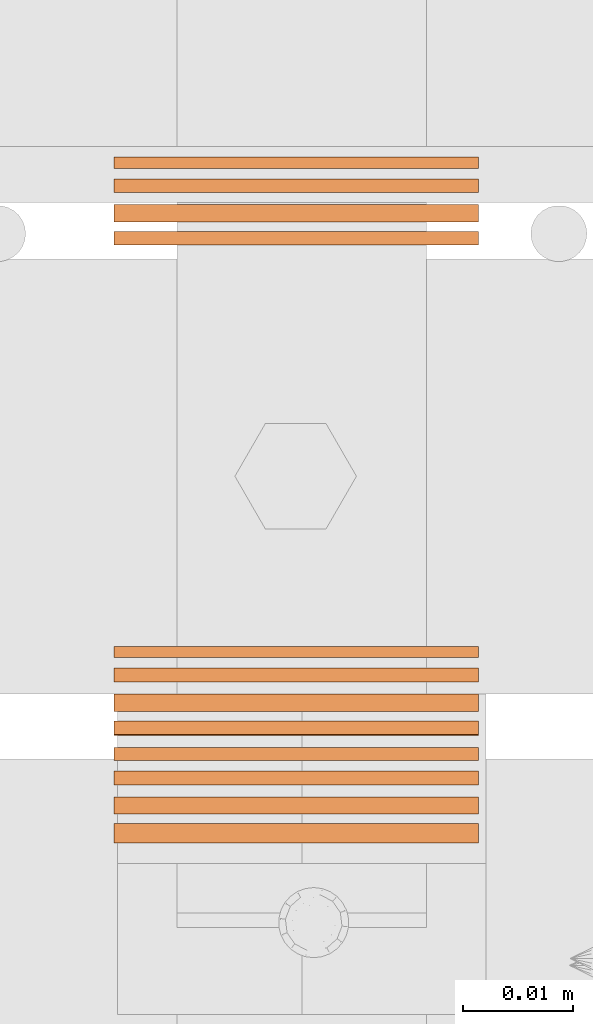
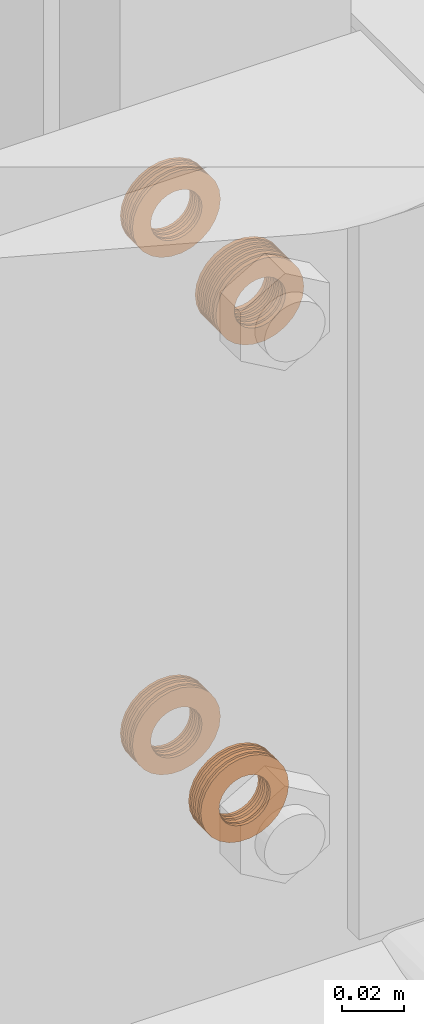
# One storey, part 39 of 44: 5 proxies.
"""IFC4 building model written with IfcOpenShell, lengths in feet."""

from ifc_helpers import new_model, entity, si_unit, converted_unit, derived_unit, direction, frame, frame_2d, origin, origin_2d_with_axis, place, context, subcontext, project, spatial, circle_curve, parameter, trimmed, segment, composite_curve, outline, extrude, source, transform, mapped, material, type_object, type_shapes, element, save


model = new_model("IFC4")

# Units and contexts
model_context = context("Model", 3, precision=0.0001, world=origin(), true_north=direction((6.12303176911189e-17, 1.0)))
body_context = subcontext(model_context, "Body", "Model", "MODEL_VIEW")
ifc_project = project(units=[converted_unit("LENGTHUNIT", "FOOT", entity("IfcRatioMeasure", 0.3048), si_unit("LENGTHUNIT", "METRE"), dimensions=[1, 0, 0, 0, 0, 0, 0]), converted_unit("AREAUNIT", "SQUARE FOOT", entity("IfcRatioMeasure", 0.09290304), si_unit("AREAUNIT", "SQUARE_METRE"), dimensions=[2, 0, 0, 0, 0, 0, 0]), converted_unit("VOLUMEUNIT", "CUBIC FOOT", entity("IfcRatioMeasure", 0.028316846592), si_unit("VOLUMEUNIT", "CUBIC_METRE"), dimensions=[3, 0, 0, 0, 0, 0, 0]), converted_unit("PLANEANGLEUNIT", "DEGREE", entity("IfcRatioMeasure", 0.0174532925199433), si_unit("PLANEANGLEUNIT", "RADIAN"), dimensions=[0, 0, 0, 0, 0, 0, 0]), si_unit("MASSUNIT", "GRAM", prefix="KILO"), derived_unit("MASSDENSITYUNIT", [(si_unit("MASSUNIT", "GRAM", prefix="KILO"), 1), (si_unit("LENGTHUNIT", "METRE"), -3)]), derived_unit("MOMENTOFINERTIAUNIT", [(si_unit("LENGTHUNIT", "METRE"), 4)]), si_unit("TIMEUNIT", "SECOND"), si_unit("FREQUENCYUNIT", "HERTZ"), si_unit("THERMODYNAMICTEMPERATUREUNIT", "DEGREE_CELSIUS"), derived_unit("THERMALTRANSMITTANCEUNIT", [(si_unit("MASSUNIT", "GRAM", prefix="KILO"), 1), (si_unit("THERMODYNAMICTEMPERATUREUNIT", "KELVIN"), -1), (si_unit("TIMEUNIT", "SECOND"), -3)]), derived_unit("VOLUMETRICFLOWRATEUNIT", [(si_unit("LENGTHUNIT", "METRE"), 3), (si_unit("TIMEUNIT", "SECOND"), -1)]), si_unit("ELECTRICCURRENTUNIT", "AMPERE"), si_unit("ELECTRICVOLTAGEUNIT", "VOLT"), si_unit("POWERUNIT", "WATT"), si_unit("FORCEUNIT", "NEWTON"), si_unit("ILLUMINANCEUNIT", "LUX"), si_unit("LUMINOUSFLUXUNIT", "LUMEN"), si_unit("LUMINOUSINTENSITYUNIT", "CANDELA"), derived_unit("USERDEFINED", [(si_unit("MASSUNIT", "GRAM", prefix="KILO"), -1), (si_unit("LENGTHUNIT", "METRE"), -2), (si_unit("TIMEUNIT", "SECOND"), 3), (si_unit("LUMINOUSFLUXUNIT", "LUMEN"), 1)]), derived_unit("LINEARVELOCITYUNIT", [(si_unit("LENGTHUNIT", "METRE"), 1), (si_unit("TIMEUNIT", "SECOND"), -1)]), si_unit("PRESSUREUNIT", "PASCAL"), derived_unit("USERDEFINED", [(si_unit("LENGTHUNIT", "METRE"), -2), (si_unit("MASSUNIT", "GRAM", prefix="KILO"), 1), (si_unit("TIMEUNIT", "SECOND"), -2)]), derived_unit("LINEARFORCEUNIT", [(si_unit("MASSUNIT", "GRAM", prefix="KILO"), 1), (si_unit("LENGTHUNIT", "METRE"), 1), (si_unit("TIMEUNIT", "SECOND"), -2), (si_unit("LENGTHUNIT", "METRE"), -1)]), derived_unit("PLANARFORCEUNIT", [(si_unit("MASSUNIT", "GRAM", prefix="KILO"), 1), (si_unit("LENGTHUNIT", "METRE"), 1), (si_unit("TIMEUNIT", "SECOND"), -2), (si_unit("LENGTHUNIT", "METRE"), -2)])], contexts=[model_context])

# Site, building, storey
site_placement = place(None, origin())
site = spatial("IfcSite", under=ifc_project, at=site_placement, CompositionType="ELEMENT")
building_placement = place(site_placement, origin())
building = spatial("IfcBuilding", under=site, at=building_placement, CompositionType="ELEMENT")
storey_placement = place(building_placement, origin())
storey = spatial("IfcBuildingStorey", under=building, at=storey_placement, CompositionType="ELEMENT", Elevation=0.0)

# Proxies
ifc_material = material(Name="(2) GALV. (FOR DRAINAGE)", Category="Materials")
building_element_proxy_type_1 = type_object("IfcBuildingElementProxyType", Name="WASHER198:WASHER", PredefinedType="NOTDEFINED", material=ifc_material)
shared_shape_1 = source(origin(), body_context, "Body", "SweptSolid", [
    extrude(outline(composite_curve([segment(trimmed(circle_curve(origin_2d_with_axis(), 0.054126587736544), [parameter(360.0)], [parameter(180.0)], True, "PARAMETER"), True, "CONTINUOUS"), segment(trimmed(circle_curve(origin_2d_with_axis(), 0.054126587736544), [parameter(180.0)], [parameter(360.0)], True, "PARAMETER"), True, "CONTINUOUS")], self_intersect=False), holes=[composite_curve([segment(trimmed(circle_curve(frame_2d((0.0, 0.00204962727015712), x_axis=(1.0, 0.0)), 0.031438579453031), [parameter(180.0)], [parameter(360.0)], True, "PARAMETER"), False, "CONTINUOUS"), segment(trimmed(circle_curve(frame_2d((0.0, 0.00204962727015712), x_axis=(1.0, 0.0)), 0.031438579453031), [parameter(360.0)], [parameter(180.0)], True, "PARAMETER"), False, "CONTINUOUS")], self_intersect=False)]), frame((0.0, 0.0593604205315437, 0.0593604205315437), z_axis=(1.0, 0.0, 0.0), x_axis=(0.0, -1.0, 0.0)), (0.0, 0.0, 1.0), 0.00332179672204802),
    extrude(outline(composite_curve([segment(trimmed(circle_curve(origin_2d_with_axis(), 0.054126587736544), [parameter(180.0)], [parameter(360.0)], True, "PARAMETER"), True, "CONTINUOUS"), segment(trimmed(circle_curve(origin_2d_with_axis(), 0.054126587736544), [parameter(360.0)], [parameter(180.0)], True, "PARAMETER"), True, "CONTINUOUS")], self_intersect=False), holes=[composite_curve([segment(trimmed(circle_curve(frame_2d((0.0, 0.00204962727015712), x_axis=(1.0, 0.0)), 0.031438579453031), [parameter(360.0)], [parameter(180.0)], True, "PARAMETER"), False, "CONTINUOUS"), segment(trimmed(circle_curve(frame_2d((0.0, 0.00204962727015712), x_axis=(1.0, 0.0)), 0.031438579453031), [parameter(180.0)], [parameter(360.0)], True, "PARAMETER"), False, "CONTINUOUS")], self_intersect=False)]), frame((0.0220636819910851, 0.0593604205315437, 0.0593604205315437), z_axis=(1.0, 0.0, 0.0), x_axis=(0.0, -1.0, 0.0)), (0.0, 0.0, 1.0), 0.00404999031002262),
    extrude(outline(composite_curve([segment(trimmed(circle_curve(origin_2d_with_axis(), 0.054126587736544), [parameter(180.0)], [parameter(360.0)], True, "PARAMETER"), True, "CONTINUOUS"), segment(trimmed(circle_curve(origin_2d_with_axis(), 0.054126587736544), [parameter(360.0)], [parameter(180.0)], True, "PARAMETER"), True, "CONTINUOUS")], self_intersect=False), holes=[composite_curve([segment(trimmed(circle_curve(frame_2d((0.0, 0.00204962727015712), x_axis=(1.0, 0.0)), 0.031438579453031), [parameter(360.0)], [parameter(180.0)], True, "PARAMETER"), False, "CONTINUOUS"), segment(trimmed(circle_curve(frame_2d((0.0, 0.00204962727015712), x_axis=(1.0, 0.0)), 0.031438579453031), [parameter(180.0)], [parameter(360.0)], True, "PARAMETER"), False, "CONTINUOUS")], self_intersect=False)]), frame((0.00642093526334975, 0.0593604205315437, 0.0593604205315437), z_axis=(1.0, 0.0, 0.0), x_axis=(0.0, -1.0, 0.0)), (0.0, 0.0, 1.0), 0.00412198282083409),
    extrude(outline(composite_curve([segment(trimmed(circle_curve(origin_2d_with_axis(), 0.054126587736544), [parameter(180.0)], [parameter(360.0)], True, "PARAMETER"), True, "CONTINUOUS"), segment(trimmed(circle_curve(origin_2d_with_axis(), 0.054126587736544), [parameter(360.0)], [parameter(180.0)], True, "PARAMETER"), True, "CONTINUOUS")], self_intersect=False), holes=[composite_curve([segment(trimmed(circle_curve(frame_2d((0.0, 0.00204962727015712), x_axis=(1.0, 0.0)), 0.031438579453031), [parameter(360.0)], [parameter(180.0)], True, "PARAMETER"), False, "CONTINUOUS"), segment(trimmed(circle_curve(frame_2d((0.0, 0.00204962727015712), x_axis=(1.0, 0.0)), 0.031438579453031), [parameter(180.0)], [parameter(360.0)], True, "PARAMETER"), False, "CONTINUOUS")], self_intersect=False)]), frame((0.0141095597130061, 0.0593604205315437, 0.0593604205315437), z_axis=(1.0, 0.0, 0.0), x_axis=(0.0, -1.0, 0.0)), (0.0, 0.0, 1.0), 0.0051228935196832),
])
type_shapes(building_element_proxy_type_1, [shared_shape_1])
proxy_1_placement = place(storey_placement, frame((1493.80418979036, 4.9172173612744, 9.5801619472998), z_axis=(0.0, 0.0, 1.0), x_axis=(0.0, -1.0, 0.0)))
element("IfcBuildingElementProxy", 1, at=proxy_1_placement, inside=storey, type_object=building_element_proxy_type_1, material=ifc_material, Name="WASHER198:WASHER", ObjectType="WASHER198:WASHER", PredefinedType="NOTDEFINED", context=body_context, shape_type="MappedRepresentation", body=[
    mapped(shared_shape_1, transform((0.0, 0.0, 0.0), scale=1.0)),
])
building_element_proxy_type_2 = type_object("IfcBuildingElementProxyType", Name="WASHER202:WASHER", PredefinedType="NOTDEFINED", material=ifc_material)
shared_shape_2 = source(origin(), body_context, "Body", "SweptSolid", [
    extrude(outline(composite_curve([segment(trimmed(circle_curve(origin_2d_with_axis(), 0.054126587736544), [parameter(360.0)], [parameter(180.0)], True, "PARAMETER"), True, "CONTINUOUS"), segment(trimmed(circle_curve(origin_2d_with_axis(), 0.054126587736544), [parameter(180.0)], [parameter(360.0)], True, "PARAMETER"), True, "CONTINUOUS")], self_intersect=False), holes=[composite_curve([segment(trimmed(circle_curve(frame_2d((0.0, 0.00204962727015712), x_axis=(1.0, 0.0)), 0.031438579453031), [parameter(180.0)], [parameter(360.0)], True, "PARAMETER"), False, "CONTINUOUS"), segment(trimmed(circle_curve(frame_2d((0.0, 0.00204962727015712), x_axis=(1.0, 0.0)), 0.031438579453031), [parameter(360.0)], [parameter(180.0)], True, "PARAMETER"), False, "CONTINUOUS")], self_intersect=False)]), frame((0.0, 0.0593604205315437, 0.0593604205315437), z_axis=(1.0, 0.0, 0.0), x_axis=(0.0, -1.0, 0.0)), (0.0, 0.0, 1.0), 0.00519959634584666),
    extrude(outline(composite_curve([segment(trimmed(circle_curve(origin_2d_with_axis(), 0.054126587736544), [parameter(180.0)], [parameter(360.0)], True, "PARAMETER"), True, "CONTINUOUS"), segment(trimmed(circle_curve(origin_2d_with_axis(), 0.054126587736544), [parameter(360.0)], [parameter(180.0)], True, "PARAMETER"), True, "CONTINUOUS")], self_intersect=False), holes=[composite_curve([segment(trimmed(circle_curve(frame_2d((0.0, 0.00204962727015712), x_axis=(1.0, 0.0)), 0.031438579453031), [parameter(360.0)], [parameter(180.0)], True, "PARAMETER"), False, "CONTINUOUS"), segment(trimmed(circle_curve(frame_2d((0.0, 0.00204962727015712), x_axis=(1.0, 0.0)), 0.031438579453031), [parameter(180.0)], [parameter(360.0)], True, "PARAMETER"), False, "CONTINUOUS")], self_intersect=False)]), frame((0.0385633439132107, 0.0593604205315437, 0.0593604205315437), z_axis=(1.0, 0.0, 0.0), x_axis=(0.0, -1.0, 0.0)), (0.0, 0.0, 1.0), 0.00570828538684509),
    extrude(outline(composite_curve([segment(trimmed(circle_curve(origin_2d_with_axis(), 0.054126587736544), [parameter(180.0)], [parameter(360.0)], True, "PARAMETER"), True, "CONTINUOUS"), segment(trimmed(circle_curve(origin_2d_with_axis(), 0.054126587736544), [parameter(360.0)], [parameter(180.0)], True, "PARAMETER"), True, "CONTINUOUS")], self_intersect=False), holes=[composite_curve([segment(trimmed(circle_curve(frame_2d((0.0, 0.00204962727015712), x_axis=(1.0, 0.0)), 0.031438579453031), [parameter(360.0)], [parameter(180.0)], True, "PARAMETER"), False, "CONTINUOUS"), segment(trimmed(circle_curve(frame_2d((0.0, 0.00204962727015712), x_axis=(1.0, 0.0)), 0.031438579453031), [parameter(180.0)], [parameter(360.0)], True, "PARAMETER"), False, "CONTINUOUS")], self_intersect=False)]), frame((0.0306092216351317, 0.0593604205315437, 0.0593604205315437), z_axis=(1.0, 0.0, 0.0), x_axis=(0.0, -1.0, 0.0)), (0.0, 0.0, 1.0), 0.0051228935196832),
    extrude(outline(composite_curve([segment(trimmed(circle_curve(origin_2d_with_axis(), 0.054126587736544), [parameter(180.0)], [parameter(360.0)], True, "PARAMETER"), True, "CONTINUOUS"), segment(trimmed(circle_curve(origin_2d_with_axis(), 0.054126587736544), [parameter(360.0)], [parameter(180.0)], True, "PARAMETER"), True, "CONTINUOUS")], self_intersect=False), holes=[composite_curve([segment(trimmed(circle_curve(frame_2d((0.0, 0.00204962727015712), x_axis=(1.0, 0.0)), 0.031438579453031), [parameter(360.0)], [parameter(180.0)], True, "PARAMETER"), False, "CONTINUOUS"), segment(trimmed(circle_curve(frame_2d((0.0, 0.00204962727015712), x_axis=(1.0, 0.0)), 0.031438579453031), [parameter(180.0)], [parameter(360.0)], True, "PARAMETER"), False, "CONTINUOUS")], self_intersect=False)]), frame((0.0159873593368047, 0.0593604205315437, 0.0593604205315437), z_axis=(1.0, 0.0, 0.0), x_axis=(0.0, -1.0, 0.0)), (0.0, 0.0, 1.0), 0.00383409930736889),
    extrude(outline(composite_curve([segment(trimmed(circle_curve(origin_2d_with_axis(), 0.054126587736544), [parameter(180.0)], [parameter(360.0)], True, "PARAMETER"), True, "CONTINUOUS"), segment(trimmed(circle_curve(origin_2d_with_axis(), 0.054126587736544), [parameter(360.0)], [parameter(180.0)], True, "PARAMETER"), True, "CONTINUOUS")], self_intersect=False), holes=[composite_curve([segment(trimmed(circle_curve(frame_2d((0.0, 0.00204962727015712), x_axis=(1.0, 0.0)), 0.031438579453031), [parameter(360.0)], [parameter(180.0)], True, "PARAMETER"), False, "CONTINUOUS"), segment(trimmed(circle_curve(frame_2d((0.0, 0.00204962727015712), x_axis=(1.0, 0.0)), 0.031438579453031), [parameter(180.0)], [parameter(360.0)], True, "PARAMETER"), False, "CONTINUOUS")], self_intersect=False)]), frame((0.0229205971854753, 0.0593604205315437, 0.0593604205315437), z_axis=(1.0, 0.0, 0.0), x_axis=(0.0, -1.0, 0.0)), (0.0, 0.0, 1.0), 0.00412198282083409),
    extrude(outline(composite_curve([segment(trimmed(circle_curve(origin_2d_with_axis(), 0.054126587736544), [parameter(180.0)], [parameter(360.0)], True, "PARAMETER"), True, "CONTINUOUS"), segment(trimmed(circle_curve(origin_2d_with_axis(), 0.054126587736544), [parameter(360.0)], [parameter(180.0)], True, "PARAMETER"), True, "CONTINUOUS")], self_intersect=False), holes=[composite_curve([segment(trimmed(circle_curve(frame_2d((0.0, 0.00204962727015712), x_axis=(1.0, 0.0)), 0.031438579453031), [parameter(360.0)], [parameter(180.0)], True, "PARAMETER"), False, "CONTINUOUS"), segment(trimmed(circle_curve(frame_2d((0.0, 0.00204962727015712), x_axis=(1.0, 0.0)), 0.031438579453031), [parameter(180.0)], [parameter(360.0)], True, "PARAMETER"), False, "CONTINUOUS")], self_intersect=False)]), frame((0.00829873488714838, 0.0593604205315437, 0.0593604205315437), z_axis=(1.0, 0.0, 0.0), x_axis=(0.0, -1.0, 0.0)), (0.0, 0.0, 1.0), 0.00412198282083409),
])
type_shapes(building_element_proxy_type_2, [shared_shape_2])
proxy_2_placement = place(storey_placement, frame((1493.80418979036, 4.75787225520091, 9.57411707518539), z_axis=(0.0, 0.0, 1.0), x_axis=(0.0, -1.0, 0.0)))
element("IfcBuildingElementProxy", 2, at=proxy_2_placement, inside=storey, type_object=building_element_proxy_type_2, material=ifc_material, Name="WASHER202:WASHER", ObjectType="WASHER202:WASHER", PredefinedType="NOTDEFINED", context=body_context, shape_type="MappedRepresentation", body=[
    mapped(shared_shape_2, transform((0.0, 0.0, 0.0), scale=1.0)),
])
building_element_proxy_type_3 = type_object("IfcBuildingElementProxyType", Name="WASHER204:WASHER", PredefinedType="NOTDEFINED", material=ifc_material)
shared_shape_3 = source(origin(), body_context, "Body", "SweptSolid", [
    extrude(outline(composite_curve([segment(trimmed(circle_curve(origin_2d_with_axis(), 0.054126587736544), [parameter(360.0)], [parameter(180.0)], True, "PARAMETER"), True, "CONTINUOUS"), segment(trimmed(circle_curve(origin_2d_with_axis(), 0.054126587736544), [parameter(180.0)], [parameter(360.0)], True, "PARAMETER"), True, "CONTINUOUS")], self_intersect=False), holes=[composite_curve([segment(trimmed(circle_curve(frame_2d((0.0, 0.00204962727015712), x_axis=(1.0, 0.0)), 0.031438579453031), [parameter(180.0)], [parameter(360.0)], True, "PARAMETER"), False, "CONTINUOUS"), segment(trimmed(circle_curve(frame_2d((0.0, 0.00204962727015712), x_axis=(1.0, 0.0)), 0.031438579453031), [parameter(360.0)], [parameter(180.0)], True, "PARAMETER"), False, "CONTINUOUS")], self_intersect=False)]), frame((0.0, 0.0593604205315437, 0.0593604205315437), z_axis=(1.0, 0.0, 0.0), x_axis=(0.0, -1.0, 0.0)), (0.0, 0.0, 1.0), 0.00332179672204802),
    extrude(outline(composite_curve([segment(trimmed(circle_curve(origin_2d_with_axis(), 0.054126587736544), [parameter(180.0)], [parameter(360.0)], True, "PARAMETER"), True, "CONTINUOUS"), segment(trimmed(circle_curve(origin_2d_with_axis(), 0.054126587736544), [parameter(360.0)], [parameter(180.0)], True, "PARAMETER"), True, "CONTINUOUS")], self_intersect=False), holes=[composite_curve([segment(trimmed(circle_curve(frame_2d((0.0, 0.00204962727015712), x_axis=(1.0, 0.0)), 0.031438579453031), [parameter(360.0)], [parameter(180.0)], True, "PARAMETER"), False, "CONTINUOUS"), segment(trimmed(circle_curve(frame_2d((0.0, 0.00204962727015712), x_axis=(1.0, 0.0)), 0.031438579453031), [parameter(180.0)], [parameter(360.0)], True, "PARAMETER"), False, "CONTINUOUS")], self_intersect=False)]), frame((0.0220636819910851, 0.0593604205315437, 0.0593604205315437), z_axis=(1.0, 0.0, 0.0), x_axis=(0.0, -1.0, 0.0)), (0.0, 0.0, 1.0), 0.00404999031002262),
    extrude(outline(composite_curve([segment(trimmed(circle_curve(origin_2d_with_axis(), 0.054126587736544), [parameter(180.0)], [parameter(360.0)], True, "PARAMETER"), True, "CONTINUOUS"), segment(trimmed(circle_curve(origin_2d_with_axis(), 0.054126587736544), [parameter(360.0)], [parameter(180.0)], True, "PARAMETER"), True, "CONTINUOUS")], self_intersect=False), holes=[composite_curve([segment(trimmed(circle_curve(frame_2d((0.0, 0.00204962727015712), x_axis=(1.0, 0.0)), 0.031438579453031), [parameter(360.0)], [parameter(180.0)], True, "PARAMETER"), False, "CONTINUOUS"), segment(trimmed(circle_curve(frame_2d((0.0, 0.00204962727015712), x_axis=(1.0, 0.0)), 0.031438579453031), [parameter(180.0)], [parameter(360.0)], True, "PARAMETER"), False, "CONTINUOUS")], self_intersect=False)]), frame((0.00642093526334975, 0.0593604205315437, 0.0593604205315437), z_axis=(1.0, 0.0, 0.0), x_axis=(0.0, -1.0, 0.0)), (0.0, 0.0, 1.0), 0.00412198282083409),
    extrude(outline(composite_curve([segment(trimmed(circle_curve(origin_2d_with_axis(), 0.054126587736544), [parameter(180.0)], [parameter(360.0)], True, "PARAMETER"), True, "CONTINUOUS"), segment(trimmed(circle_curve(origin_2d_with_axis(), 0.054126587736544), [parameter(360.0)], [parameter(180.0)], True, "PARAMETER"), True, "CONTINUOUS")], self_intersect=False), holes=[composite_curve([segment(trimmed(circle_curve(frame_2d((0.0, 0.00204962727015712), x_axis=(1.0, 0.0)), 0.031438579453031), [parameter(360.0)], [parameter(180.0)], True, "PARAMETER"), False, "CONTINUOUS"), segment(trimmed(circle_curve(frame_2d((0.0, 0.00204962727015712), x_axis=(1.0, 0.0)), 0.031438579453031), [parameter(180.0)], [parameter(360.0)], True, "PARAMETER"), False, "CONTINUOUS")], self_intersect=False)]), frame((0.0141095597130061, 0.0593604205315437, 0.0593604205315437), z_axis=(1.0, 0.0, 0.0), x_axis=(0.0, -1.0, 0.0)), (0.0, 0.0, 1.0), 0.0051228935196832),
])
type_shapes(building_element_proxy_type_3, [shared_shape_3])
proxy_3_placement = place(storey_placement, frame((1493.80418979036, 4.9172173612744, 8.90822083537735), z_axis=(0.0, 0.0, 1.0), x_axis=(0.0, -1.0, 0.0)))
element("IfcBuildingElementProxy", 3, at=proxy_3_placement, inside=storey, type_object=building_element_proxy_type_3, material=ifc_material, Name="WASHER204:WASHER", ObjectType="WASHER204:WASHER", PredefinedType="NOTDEFINED", context=body_context, shape_type="MappedRepresentation", body=[
    mapped(shared_shape_3, transform((0.0, 0.0, 0.0), scale=1.0)),
])
building_element_proxy_type_4 = type_object("IfcBuildingElementProxyType", Name="WASHER205:WASHER", PredefinedType="NOTDEFINED", material=ifc_material)
shared_shape_4 = source(origin(), body_context, "Body", "SweptSolid", [
    extrude(outline(composite_curve([segment(trimmed(circle_curve(origin_2d_with_axis(), 0.054126587736544), [parameter(360.0)], [parameter(180.0)], True, "PARAMETER"), True, "CONTINUOUS"), segment(trimmed(circle_curve(origin_2d_with_axis(), 0.054126587736544), [parameter(180.0)], [parameter(360.0)], True, "PARAMETER"), True, "CONTINUOUS")], self_intersect=False), holes=[composite_curve([segment(trimmed(circle_curve(frame_2d((0.0, 0.00204962727015712), x_axis=(1.0, 0.0)), 0.031438579453031), [parameter(180.0)], [parameter(360.0)], True, "PARAMETER"), False, "CONTINUOUS"), segment(trimmed(circle_curve(frame_2d((0.0, 0.00204962727015712), x_axis=(1.0, 0.0)), 0.031438579453031), [parameter(360.0)], [parameter(180.0)], True, "PARAMETER"), False, "CONTINUOUS")], self_intersect=False)]), frame((0.0, 0.0593604205315437, 0.0593604205315437), z_axis=(1.0, 0.0, 0.0), x_axis=(0.0, -1.0, 0.0)), (0.0, 0.0, 1.0), 0.00332179672204802),
    extrude(outline(composite_curve([segment(trimmed(circle_curve(origin_2d_with_axis(), 0.054126587736544), [parameter(180.0)], [parameter(360.0)], True, "PARAMETER"), True, "CONTINUOUS"), segment(trimmed(circle_curve(origin_2d_with_axis(), 0.054126587736544), [parameter(360.0)], [parameter(180.0)], True, "PARAMETER"), True, "CONTINUOUS")], self_intersect=False), holes=[composite_curve([segment(trimmed(circle_curve(frame_2d((0.0, 0.00204962727015712), x_axis=(1.0, 0.0)), 0.031438579453031), [parameter(360.0)], [parameter(180.0)], True, "PARAMETER"), False, "CONTINUOUS"), segment(trimmed(circle_curve(frame_2d((0.0, 0.00204962727015712), x_axis=(1.0, 0.0)), 0.031438579453031), [parameter(180.0)], [parameter(360.0)], True, "PARAMETER"), False, "CONTINUOUS")], self_intersect=False)]), frame((0.0220636819910851, 0.0593604205315437, 0.0593604205315437), z_axis=(1.0, 0.0, 0.0), x_axis=(0.0, -1.0, 0.0)), (0.0, 0.0, 1.0), 0.00404999031002262),
    extrude(outline(composite_curve([segment(trimmed(circle_curve(origin_2d_with_axis(), 0.054126587736544), [parameter(180.0)], [parameter(360.0)], True, "PARAMETER"), True, "CONTINUOUS"), segment(trimmed(circle_curve(origin_2d_with_axis(), 0.054126587736544), [parameter(360.0)], [parameter(180.0)], True, "PARAMETER"), True, "CONTINUOUS")], self_intersect=False), holes=[composite_curve([segment(trimmed(circle_curve(frame_2d((0.0, 0.00204962727015712), x_axis=(1.0, 0.0)), 0.031438579453031), [parameter(360.0)], [parameter(180.0)], True, "PARAMETER"), False, "CONTINUOUS"), segment(trimmed(circle_curve(frame_2d((0.0, 0.00204962727015712), x_axis=(1.0, 0.0)), 0.031438579453031), [parameter(180.0)], [parameter(360.0)], True, "PARAMETER"), False, "CONTINUOUS")], self_intersect=False)]), frame((0.00642093526334975, 0.0593604205315437, 0.0593604205315437), z_axis=(1.0, 0.0, 0.0), x_axis=(0.0, -1.0, 0.0)), (0.0, 0.0, 1.0), 0.00412198282083409),
    extrude(outline(composite_curve([segment(trimmed(circle_curve(origin_2d_with_axis(), 0.054126587736544), [parameter(180.0)], [parameter(360.0)], True, "PARAMETER"), True, "CONTINUOUS"), segment(trimmed(circle_curve(origin_2d_with_axis(), 0.054126587736544), [parameter(360.0)], [parameter(180.0)], True, "PARAMETER"), True, "CONTINUOUS")], self_intersect=False), holes=[composite_curve([segment(trimmed(circle_curve(frame_2d((0.0, 0.00204962727015712), x_axis=(1.0, 0.0)), 0.031438579453031), [parameter(360.0)], [parameter(180.0)], True, "PARAMETER"), False, "CONTINUOUS"), segment(trimmed(circle_curve(frame_2d((0.0, 0.00204962727015712), x_axis=(1.0, 0.0)), 0.031438579453031), [parameter(180.0)], [parameter(360.0)], True, "PARAMETER"), False, "CONTINUOUS")], self_intersect=False)]), frame((0.0141095597130061, 0.0593604205315437, 0.0593604205315437), z_axis=(1.0, 0.0, 0.0), x_axis=(0.0, -1.0, 0.0)), (0.0, 0.0, 1.0), 0.0051228935196832),
])
type_shapes(building_element_proxy_type_4, [shared_shape_4])
proxy_4_placement = place(storey_placement, frame((1493.80418979036, 4.77190511208776, 8.90822083537735), z_axis=(0.0, 0.0, 1.0), x_axis=(0.0, -1.0, 0.0)))
element("IfcBuildingElementProxy", 4, at=proxy_4_placement, inside=storey, type_object=building_element_proxy_type_4, material=ifc_material, Name="WASHER205:WASHER", ObjectType="WASHER205:WASHER", PredefinedType="NOTDEFINED", context=body_context, shape_type="MappedRepresentation", body=[
    mapped(shared_shape_4, transform((0.0, 0.0, 0.0), scale=1.0)),
])
building_element_proxy_type_5 = type_object("IfcBuildingElementProxyType", Name="WASHER238:WASHER", PredefinedType="NOTDEFINED", material=ifc_material)
shared_shape_5 = source(origin(), body_context, "Body", "SweptSolid", [
    extrude(outline(composite_curve([segment(trimmed(circle_curve(origin_2d_with_axis(), 0.054126587736544), [parameter(360.0)], [parameter(180.0)], True, "PARAMETER"), True, "CONTINUOUS"), segment(trimmed(circle_curve(origin_2d_with_axis(), 0.054126587736544), [parameter(180.0)], [parameter(360.0)], True, "PARAMETER"), True, "CONTINUOUS")], self_intersect=False), holes=[composite_curve([segment(trimmed(circle_curve(frame_2d((0.0, 0.00204962727015712), x_axis=(1.0, 0.0)), 0.031438579453031), [parameter(180.0)], [parameter(360.0)], True, "PARAMETER"), False, "CONTINUOUS"), segment(trimmed(circle_curve(frame_2d((0.0, 0.00204962727015712), x_axis=(1.0, 0.0)), 0.031438579453031), [parameter(360.0)], [parameter(180.0)], True, "PARAMETER"), False, "CONTINUOUS")], self_intersect=False)]), frame((0.0, 0.0593604205315437, 0.0593604205315437), z_axis=(1.0, 0.0, 0.0), x_axis=(0.0, -1.0, 0.0)), (0.0, 0.0, 1.0), 0.00332179672204802),
    extrude(outline(composite_curve([segment(trimmed(circle_curve(origin_2d_with_axis(), 0.054126587736544), [parameter(180.0)], [parameter(360.0)], True, "PARAMETER"), True, "CONTINUOUS"), segment(trimmed(circle_curve(origin_2d_with_axis(), 0.054126587736544), [parameter(360.0)], [parameter(180.0)], True, "PARAMETER"), True, "CONTINUOUS")], self_intersect=False), holes=[composite_curve([segment(trimmed(circle_curve(frame_2d((0.0, 0.00204962727015712), x_axis=(1.0, 0.0)), 0.031438579453031), [parameter(360.0)], [parameter(180.0)], True, "PARAMETER"), False, "CONTINUOUS"), segment(trimmed(circle_curve(frame_2d((0.0, 0.00204962727015712), x_axis=(1.0, 0.0)), 0.031438579453031), [parameter(180.0)], [parameter(360.0)], True, "PARAMETER"), False, "CONTINUOUS")], self_intersect=False)]), frame((0.0220636819910851, 0.0593604205315437, 0.0593604205315437), z_axis=(1.0, 0.0, 0.0), x_axis=(0.0, -1.0, 0.0)), (0.0, 0.0, 1.0), 0.00404999031002262),
    extrude(outline(composite_curve([segment(trimmed(circle_curve(origin_2d_with_axis(), 0.054126587736544), [parameter(180.0)], [parameter(360.0)], True, "PARAMETER"), True, "CONTINUOUS"), segment(trimmed(circle_curve(origin_2d_with_axis(), 0.054126587736544), [parameter(360.0)], [parameter(180.0)], True, "PARAMETER"), True, "CONTINUOUS")], self_intersect=False), holes=[composite_curve([segment(trimmed(circle_curve(frame_2d((0.0, 0.00204962727015712), x_axis=(1.0, 0.0)), 0.031438579453031), [parameter(360.0)], [parameter(180.0)], True, "PARAMETER"), False, "CONTINUOUS"), segment(trimmed(circle_curve(frame_2d((0.0, 0.00204962727015712), x_axis=(1.0, 0.0)), 0.031438579453031), [parameter(180.0)], [parameter(360.0)], True, "PARAMETER"), False, "CONTINUOUS")], self_intersect=False)]), frame((0.00642093526334975, 0.0593604205315437, 0.0593604205315437), z_axis=(1.0, 0.0, 0.0), x_axis=(0.0, -1.0, 0.0)), (0.0, 0.0, 1.0), 0.00412198282083409),
    extrude(outline(composite_curve([segment(trimmed(circle_curve(origin_2d_with_axis(), 0.054126587736544), [parameter(180.0)], [parameter(360.0)], True, "PARAMETER"), True, "CONTINUOUS"), segment(trimmed(circle_curve(origin_2d_with_axis(), 0.054126587736544), [parameter(360.0)], [parameter(180.0)], True, "PARAMETER"), True, "CONTINUOUS")], self_intersect=False), holes=[composite_curve([segment(trimmed(circle_curve(frame_2d((0.0, 0.00204962727015712), x_axis=(1.0, 0.0)), 0.031438579453031), [parameter(360.0)], [parameter(180.0)], True, "PARAMETER"), False, "CONTINUOUS"), segment(trimmed(circle_curve(frame_2d((0.0, 0.00204962727015712), x_axis=(1.0, 0.0)), 0.031438579453031), [parameter(180.0)], [parameter(360.0)], True, "PARAMETER"), False, "CONTINUOUS")], self_intersect=False)]), frame((0.0141095597130061, 0.0593604205315437, 0.0593604205315437), z_axis=(1.0, 0.0, 0.0), x_axis=(0.0, -1.0, 0.0)), (0.0, 0.0, 1.0), 0.0051228935196832),
])
type_shapes(building_element_proxy_type_5, [shared_shape_5])
proxy_5_placement = place(storey_placement, frame((1493.80418979036, 4.77190511208776, 8.90822083537735), z_axis=(0.0, 0.0, 1.0), x_axis=(0.0, -1.0, 0.0)))
element("IfcBuildingElementProxy", 5, at=proxy_5_placement, inside=storey, type_object=building_element_proxy_type_5, material=ifc_material, Name="WASHER238:WASHER", ObjectType="WASHER238:WASHER", PredefinedType="NOTDEFINED", context=body_context, shape_type="MappedRepresentation", body=[
    mapped(shared_shape_5, transform((0.0, 0.0, 0.0), scale=1.0)),
])

save(model, "model.ifc")
